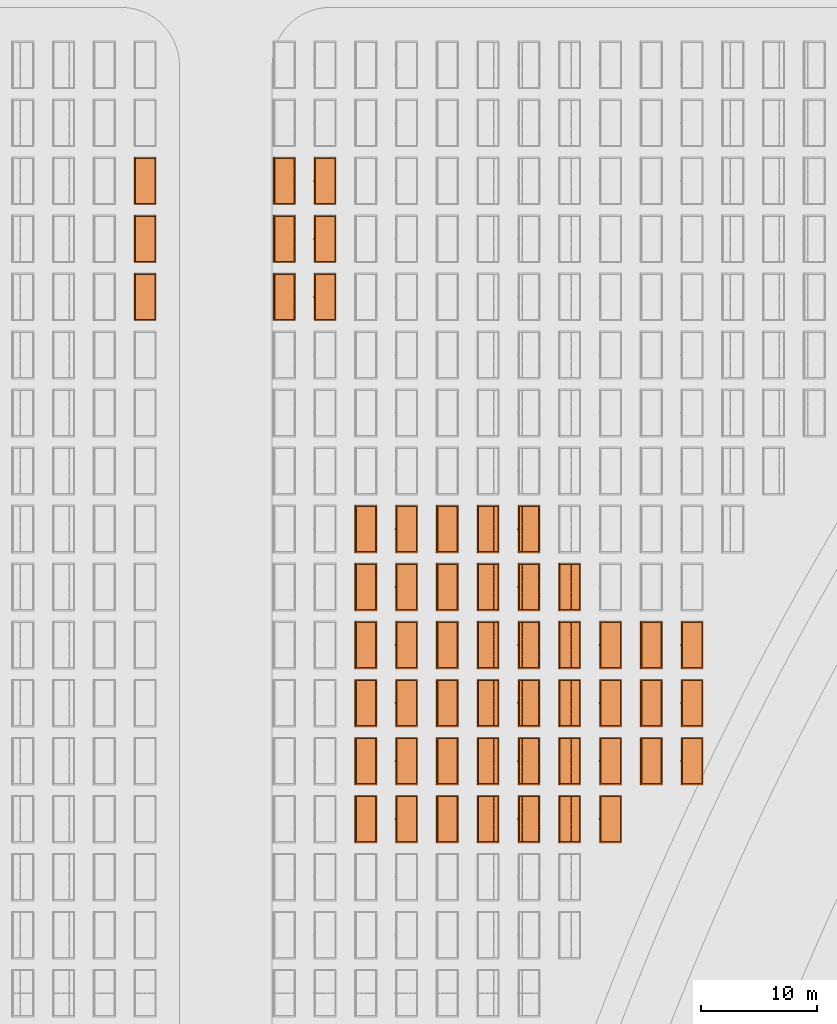
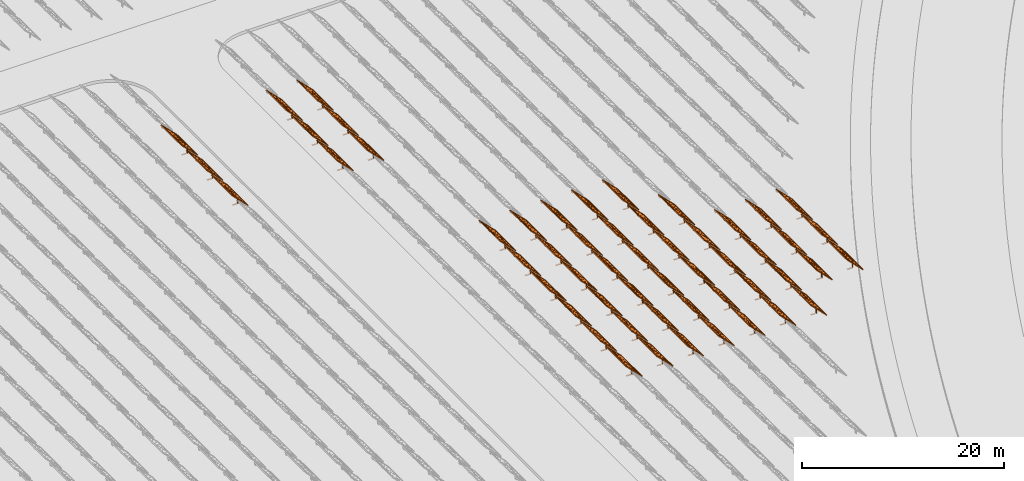
# One storey, part 30 of 39: 54 proxies.
"""IFC2X3 building model written with IfcOpenShell, lengths in millimetres."""

from ifc_helpers import new_model, entity, si_unit, converted_unit, derived_unit, direction, frame, frame_2d, origin, origin_2d_with_axis, place, context, subcontext, project, spatial, polyline, rectangle, outline, extrude, source, transform, mapped, material, material_list, element, save


model = new_model("IFC2X3")

# Units and contexts
model_context = context("Model", 3, precision=1e-06, world=origin(), true_north=direction((2.0, 6.12303176911189e-17, 1.0)))
context_of_model = context(None, 3, precision=1e-06, world=origin(), true_north=direction((2.0, 6.12303176911189e-17, 1.0)))
body_context = subcontext(model_context, "Body", "Model", "MODEL_VIEW")
ifc_project = project(units=[si_unit("LENGTHUNIT", "METRE", prefix="MILLI"), si_unit("AREAUNIT", "SQUARE_METRE", prefix="MILLI"), si_unit("VOLUMEUNIT", "CUBIC_METRE", prefix="MILLI"), converted_unit("PLANEANGLEUNIT", "DEGREE", entity("IfcRatioMeasure", 0.0174532925199433), si_unit("PLANEANGLEUNIT", "RADIAN"), dimensions=[0, 0, 0, 0, 0, 0, 0]), si_unit("MASSUNIT", "GRAM", prefix="KILO"), si_unit("TIMEUNIT", "SECOND"), si_unit("THERMODYNAMICTEMPERATUREUNIT", "KELVIN"), derived_unit("THERMALTRANSMITTANCEUNIT", [(si_unit("MASSUNIT", "GRAM", prefix="KILO"), 1), (si_unit("THERMODYNAMICTEMPERATUREUNIT", "KELVIN"), -1), (si_unit("TIMEUNIT", "SECOND"), -3)]), derived_unit("VOLUMETRICFLOWRATEUNIT", [(si_unit("LENGTHUNIT", "METRE"), 3), (si_unit("TIMEUNIT", "SECOND"), -1)])], contexts=[model_context, context_of_model])

# Site, building, storey
site_placement = place(None, origin())
site = spatial("IfcSite", under=ifc_project, at=site_placement, CompositionType="ELEMENT")
building_placement = place(site_placement, origin())
building = spatial("IfcBuilding", under=site, at=building_placement, CompositionType="ELEMENT")
storey_placement = place(building_placement, frame((0.0, 0.0, 4000.0)))
storey = spatial("IfcBuildingStorey", under=building, at=storey_placement, Name="Level 2", CompositionType="ELEMENT", Elevation=4000.0)

# Proxies
ifc_material_1 = material(Name="Stand-Steel")
ifc_material_2 = material(Name="Aluminium")
ifc_material_3 = material(Name="Glass")
ifc_material_list_1 = material_list([ifc_material_1, ifc_material_2, ifc_material_3])
shared_shape = source(origin(), body_context, "Body", "SweptSolid", [
    extrude(outline(polyline([(-629.526235435404, -220.0), (329.763117717702, -220.0), (329.763117717703, 410.0), (299.763117717703, 410.0), (299.763117717702, -190.0), (-629.526235435404, -190.0), (-629.526235435404, -220.0)])), frame((-190.00003127179, -100.0, 299.763117717707), z_axis=(0.0, 1.0, 0.0), x_axis=(0.0, 0.0, -1.0)), (0.0, 0.0, 1.0), 200.0),
    extrude(rectangle(XDim=20.0000000000001, YDim=200.0, at=frame_2d((0.0, -7.105427357601e-14), x_axis=(0.0, 1.0))), frame((-7.07109908365613, 0.0, 922.21828534124), z_axis=(-0.70710678118654, 0.0, 0.707106781186555), x_axis=(0.0, 1.0, 0.0)), (0.0, 0.0, 1.0), 2600.0),
    extrude(rectangle(XDim=24.9999999999997, YDim=24.9999999999999, at=frame_2d((2.87769807982841e-13, -9.50350909079134e-14), x_axis=(1.0, 0.0))), frame((-1449.56292018118, -1950.0, 2449.57494522722), z_axis=(0.0, 1.0, 0.0), x_axis=(-0.707106781186548, 0.0, -0.707106781186548)), (0.0, 0.0, 1.0), 3900.0),
    extrude(rectangle(XDim=24.9999999999999, YDim=25.0000000000001, at=origin_2d_with_axis()), frame((-1096.0095295879, -1950.0, 2096.02155463395), z_axis=(0.0, 1.0, 0.0), x_axis=(-0.707106781186542, 0.0, -0.707106781186553)), (0.0, 0.0, 1.0), 3900.0),
    extrude(rectangle(XDim=24.9999999999999, YDim=25.0000000000001, at=origin_2d_with_axis()), frame((-742.456138994631, -1950.0, 1742.46816404067), z_axis=(0.0, 1.0, 0.0), x_axis=(-0.707106781186542, 0.0, -0.707106781186553)), (0.0, 0.0, 1.0), 3900.0),
    extrude(rectangle(XDim=25.0, YDim=24.9999999999997, at=frame_2d((-7.19424519957101e-14, 1.19904086659517e-13), x_axis=(1.0, 0.0))), frame((-388.902748401358, -1950.0, 1388.9147734474), z_axis=(0.0, 1.0, 0.0), x_axis=(-0.707106781186545, 0.0, -0.70710678118655)), (0.0, 0.0, 1.0), 3900.0),
    extrude(rectangle(XDim=25.0000000000002, YDim=25.0, at=frame_2d((1.35891298214119e-13, 6.21724893790088e-15), x_axis=(0.0, 1.0))), frame((-35.3553703311048, 1500.0, 1035.35537033109), z_axis=(-0.707106781186544, 0.0, 0.707106781186551), x_axis=(0.0, 1.0, 0.0)), (0.0, 0.0, 1.0), 2440.0),
    extrude(rectangle(XDim=25.0000000000002, YDim=25.0, at=frame_2d((0.0, 1.77635683940025e-15), x_axis=(0.0, 1.0))), frame((-35.3553703311059, 1000.0, 1035.35537033109), z_axis=(-0.707106781186546, 0.0, 0.707106781186549), x_axis=(0.0, 1.0, 0.0)), (0.0, 0.0, 1.0), 2440.0),
    extrude(rectangle(XDim=25.0000000000002, YDim=25.0, at=frame_2d((0.0, 8.43769498715119e-14), x_axis=(0.0, 1.0))), frame((-26.5165355662756, 0.0, 1044.19420509593), z_axis=(-0.707106781186546, 0.0, 0.707106781186549), x_axis=(0.0, -1.0, 0.0)), (0.0, 0.0, 1.0), 2440.0),
    extrude(rectangle(XDim=25.0000000000002, YDim=25.0, at=frame_2d((0.0, 8.88178419700125e-16), x_axis=(0.0, 1.0))), frame((-35.3553703311065, 500.0, 1035.35537033109), z_axis=(-0.707106781186546, 0.0, 0.707106781186549), x_axis=(0.0, 1.0, 0.0)), (0.0, 0.0, 1.0), 2440.0),
    extrude(rectangle(XDim=25.0000000000002, YDim=25.0, at=frame_2d((0.0, 8.88178419700125e-16), x_axis=(0.0, 1.0))), frame((-35.3553703311086, -500.0, 1035.35537033109), z_axis=(-0.707106781186546, 0.0, 0.707106781186549), x_axis=(0.0, 1.0, 0.0)), (0.0, 0.0, 1.0), 2440.0),
    extrude(rectangle(XDim=25.0000000000002, YDim=25.0, at=frame_2d((0.0, 8.88178419700125e-16), x_axis=(0.0, 1.0))), frame((-35.3553703311095, -1000.0, 1035.35537033109), z_axis=(-0.707106781186546, 0.0, 0.707106781186549), x_axis=(0.0, 1.0, 0.0)), (0.0, 0.0, 1.0), 2440.0),
    extrude(rectangle(XDim=25.0000000000002, YDim=25.0, at=frame_2d((1.35891298214119e-13, 1.77635683940025e-15), x_axis=(0.0, 1.0))), frame((-35.3553703311107, -1500.0, 1035.35537033109), z_axis=(-0.707106781186546, 0.0, 0.707106781186549), x_axis=(0.0, 1.0, 0.0)), (0.0, 0.0, 1.0), 2440.0),
    extrude(rectangle(XDim=2400.0, YDim=11.9999999999994, at=frame_2d((-1.13686837721616e-13, 2.02948768901479e-13), x_axis=(1.0, 0.0))), frame((-883.883507754966, -1950.0, 1883.88350775495), z_axis=(0.0, 1.0, 0.0), x_axis=(0.707106781186546, 0.0, -0.707106781186549)), (0.0, 0.0, 1.0), 3900.0),
    extrude(outline(polyline([(-2050.0, -1300.0), (2050.0, -1300.0), (2050.0, 1300.0), (-2050.0, 1300.0), (-2050.0, -1300.0)]), holes=[polyline([(1950.0, -1200.0), (-1950.0, -1200.0), (-1950.0, 1200.0), (1950.0, 1200.0), (1950.0, -1200.0)])]), frame((-919.238846814293, 0.0, 1848.52816869563), z_axis=(0.707106781186554, 0.0, 0.707106781186541), x_axis=(0.0, 1.0, 0.0)), (0.0, 0.0, 1.0), 99.9999999999898),
])
proxy_1_placement = place(storey_placement, frame((-140870.317940101, 565144.680552408, 30.0)))
element("IfcBuildingElementProxy", 1, at=proxy_1_placement, inside=storey, material=ifc_material_list_1, Name="Solar Panel_4000X2500:Solar Panel_4000X2500", ObjectType="Solar Panel_4000X2500", CompositionType="ELEMENT", context=body_context, shape_type="MappedRepresentation", body=[
    mapped(shared_shape, transform((0.0, 0.0, 0.0), scale=1.0)),
])
ifc_material_list_2 = material_list([ifc_material_1, ifc_material_2, ifc_material_3])
proxy_2_placement = place(storey_placement, frame((-137355.307568371, 565144.680552408, 30.0)))
element("IfcBuildingElementProxy", 2, at=proxy_2_placement, inside=storey, material=ifc_material_list_2, Name="Solar Panel_4000X2500:Solar Panel_4000X2500", ObjectType="Solar Panel_4000X2500", CompositionType="ELEMENT", context=body_context, shape_type="MappedRepresentation", body=[
    mapped(shared_shape, transform((0.0, 0.0, 0.0), scale=1.0)),
])
ifc_material_list_3 = material_list([ifc_material_1, ifc_material_2, ifc_material_3])
proxy_3_placement = place(storey_placement, frame((-133840.297196641, 565144.680552408, 30.0)))
element("IfcBuildingElementProxy", 3, at=proxy_3_placement, inside=storey, material=ifc_material_list_3, Name="Solar Panel_4000X2500:Solar Panel_4000X2500", ObjectType="Solar Panel_4000X2500", CompositionType="ELEMENT", context=body_context, shape_type="MappedRepresentation", body=[
    mapped(shared_shape, transform((0.0, 0.0, 0.0), scale=1.0)),
])
ifc_material_list_4 = material_list([ifc_material_1, ifc_material_2, ifc_material_3])
proxy_4_placement = place(storey_placement, frame((-130325.286824911, 565144.680552408, 30.0)))
element("IfcBuildingElementProxy", 4, at=proxy_4_placement, inside=storey, material=ifc_material_list_4, Name="Solar Panel_4000X2500:Solar Panel_4000X2500", ObjectType="Solar Panel_4000X2500", CompositionType="ELEMENT", context=body_context, shape_type="MappedRepresentation", body=[
    mapped(shared_shape, transform((0.0, 0.0, 0.0), scale=1.0)),
])
ifc_material_list_5 = material_list([ifc_material_1, ifc_material_2, ifc_material_3])
proxy_5_placement = place(storey_placement, frame((-140870.317940101, 570144.680552408, 30.0)))
element("IfcBuildingElementProxy", 5, at=proxy_5_placement, inside=storey, material=ifc_material_list_5, Name="Solar Panel_4000X2500:Solar Panel_4000X2500", ObjectType="Solar Panel_4000X2500", CompositionType="ELEMENT", context=body_context, shape_type="MappedRepresentation", body=[
    mapped(shared_shape, transform((0.0, 0.0, 0.0), scale=1.0)),
])
ifc_material_list_6 = material_list([ifc_material_1, ifc_material_2, ifc_material_3])
proxy_6_placement = place(storey_placement, frame((-137355.307568371, 570144.680552408, 30.0)))
element("IfcBuildingElementProxy", 6, at=proxy_6_placement, inside=storey, material=ifc_material_list_6, Name="Solar Panel_4000X2500:Solar Panel_4000X2500", ObjectType="Solar Panel_4000X2500", CompositionType="ELEMENT", context=body_context, shape_type="MappedRepresentation", body=[
    mapped(shared_shape, transform((0.0, 0.0, 0.0), scale=1.0)),
])
ifc_material_list_7 = material_list([ifc_material_1, ifc_material_2, ifc_material_3])
proxy_7_placement = place(storey_placement, frame((-133840.297196641, 570144.680552408, 30.0)))
element("IfcBuildingElementProxy", 7, at=proxy_7_placement, inside=storey, material=ifc_material_list_7, Name="Solar Panel_4000X2500:Solar Panel_4000X2500", ObjectType="Solar Panel_4000X2500", CompositionType="ELEMENT", context=body_context, shape_type="MappedRepresentation", body=[
    mapped(shared_shape, transform((0.0, 0.0, 0.0), scale=1.0)),
])
ifc_material_list_8 = material_list([ifc_material_1, ifc_material_2, ifc_material_3])
proxy_8_placement = place(storey_placement, frame((-130325.286824911, 570144.680552408, 30.0)))
element("IfcBuildingElementProxy", 8, at=proxy_8_placement, inside=storey, material=ifc_material_list_8, Name="Solar Panel_4000X2500:Solar Panel_4000X2500", ObjectType="Solar Panel_4000X2500", CompositionType="ELEMENT", context=body_context, shape_type="MappedRepresentation", body=[
    mapped(shared_shape, transform((0.0, 0.0, 0.0), scale=1.0)),
])
ifc_material_list_9 = material_list([ifc_material_1, ifc_material_2, ifc_material_3])
proxy_9_placement = place(storey_placement, frame((-140870.317940101, 575144.680552408, 30.0)))
element("IfcBuildingElementProxy", 9, at=proxy_9_placement, inside=storey, material=ifc_material_list_9, Name="Solar Panel_4000X2500:Solar Panel_4000X2500", ObjectType="Solar Panel_4000X2500", CompositionType="ELEMENT", context=body_context, shape_type="MappedRepresentation", body=[
    mapped(shared_shape, transform((0.0, 0.0, 0.0), scale=1.0)),
])
ifc_material_list_10 = material_list([ifc_material_1, ifc_material_2, ifc_material_3])
proxy_10_placement = place(storey_placement, frame((-137355.307568371, 575144.680552408, 30.0)))
element("IfcBuildingElementProxy", 10, at=proxy_10_placement, inside=storey, material=ifc_material_list_10, Name="Solar Panel_4000X2500:Solar Panel_4000X2500", ObjectType="Solar Panel_4000X2500", CompositionType="ELEMENT", context=body_context, shape_type="MappedRepresentation", body=[
    mapped(shared_shape, transform((0.0, 0.0, 0.0), scale=1.0)),
])
ifc_material_list_11 = material_list([ifc_material_1, ifc_material_2, ifc_material_3])
proxy_11_placement = place(storey_placement, frame((-133840.297196641, 575144.680552408, 30.0)))
element("IfcBuildingElementProxy", 11, at=proxy_11_placement, inside=storey, material=ifc_material_list_11, Name="Solar Panel_4000X2500:Solar Panel_4000X2500", ObjectType="Solar Panel_4000X2500", CompositionType="ELEMENT", context=body_context, shape_type="MappedRepresentation", body=[
    mapped(shared_shape, transform((0.0, 0.0, 0.0), scale=1.0)),
])
ifc_material_list_12 = material_list([ifc_material_1, ifc_material_2, ifc_material_3])
proxy_12_placement = place(storey_placement, frame((-130325.286824911, 575144.680552408, 30.0)))
element("IfcBuildingElementProxy", 12, at=proxy_12_placement, inside=storey, material=ifc_material_list_12, Name="Solar Panel_4000X2500:Solar Panel_4000X2500", ObjectType="Solar Panel_4000X2500", CompositionType="ELEMENT", context=body_context, shape_type="MappedRepresentation", body=[
    mapped(shared_shape, transform((0.0, 0.0, 0.0), scale=1.0)),
])
ifc_material_list_13 = material_list([ifc_material_1, ifc_material_2, ifc_material_3])
proxy_13_placement = place(storey_placement, frame((-140870.317940101, 580144.680552408, 30.0)))
element("IfcBuildingElementProxy", 13, at=proxy_13_placement, inside=storey, material=ifc_material_list_13, Name="Solar Panel_4000X2500:Solar Panel_4000X2500", ObjectType="Solar Panel_4000X2500", CompositionType="ELEMENT", context=body_context, shape_type="MappedRepresentation", body=[
    mapped(shared_shape, transform((0.0, 0.0, 0.0), scale=1.0)),
])
ifc_material_list_14 = material_list([ifc_material_1, ifc_material_2, ifc_material_3])
proxy_14_placement = place(storey_placement, frame((-137355.307568371, 580144.680552408, 30.0)))
element("IfcBuildingElementProxy", 14, at=proxy_14_placement, inside=storey, material=ifc_material_list_14, Name="Solar Panel_4000X2500:Solar Panel_4000X2500", ObjectType="Solar Panel_4000X2500", CompositionType="ELEMENT", context=body_context, shape_type="MappedRepresentation", body=[
    mapped(shared_shape, transform((0.0, 0.0, 0.0), scale=1.0)),
])
ifc_material_list_15 = material_list([ifc_material_1, ifc_material_2, ifc_material_3])
proxy_15_placement = place(storey_placement, frame((-133840.297196641, 580144.680552408, 30.0)))
element("IfcBuildingElementProxy", 15, at=proxy_15_placement, inside=storey, material=ifc_material_list_15, Name="Solar Panel_4000X2500:Solar Panel_4000X2500", ObjectType="Solar Panel_4000X2500", CompositionType="ELEMENT", context=body_context, shape_type="MappedRepresentation", body=[
    mapped(shared_shape, transform((0.0, 0.0, 0.0), scale=1.0)),
])
ifc_material_list_16 = material_list([ifc_material_1, ifc_material_2, ifc_material_3])
proxy_16_placement = place(storey_placement, frame((-130325.286824911, 580144.680552408, 30.0)))
element("IfcBuildingElementProxy", 16, at=proxy_16_placement, inside=storey, material=ifc_material_list_16, Name="Solar Panel_4000X2500:Solar Panel_4000X2500", ObjectType="Solar Panel_4000X2500", CompositionType="ELEMENT", context=body_context, shape_type="MappedRepresentation", body=[
    mapped(shared_shape, transform((0.0, 0.0, 0.0), scale=1.0)),
])
ifc_material_list_17 = material_list([ifc_material_1, ifc_material_2, ifc_material_3])
proxy_17_placement = place(storey_placement, frame((-140870.317940101, 585144.680552408, 30.0)))
element("IfcBuildingElementProxy", 17, at=proxy_17_placement, inside=storey, material=ifc_material_list_17, Name="Solar Panel_4000X2500:Solar Panel_4000X2500", ObjectType="Solar Panel_4000X2500", CompositionType="ELEMENT", context=body_context, shape_type="MappedRepresentation", body=[
    mapped(shared_shape, transform((0.0, 0.0, 0.0), scale=1.0)),
])
ifc_material_list_18 = material_list([ifc_material_1, ifc_material_2, ifc_material_3])
proxy_18_placement = place(storey_placement, frame((-137355.307568371, 585144.680552408, 30.0)))
element("IfcBuildingElementProxy", 18, at=proxy_18_placement, inside=storey, material=ifc_material_list_18, Name="Solar Panel_4000X2500:Solar Panel_4000X2500", ObjectType="Solar Panel_4000X2500", CompositionType="ELEMENT", context=body_context, shape_type="MappedRepresentation", body=[
    mapped(shared_shape, transform((0.0, 0.0, 0.0), scale=1.0)),
])
ifc_material_list_19 = material_list([ifc_material_1, ifc_material_2, ifc_material_3])
proxy_19_placement = place(storey_placement, frame((-133840.297196641, 585144.680552408, 30.0)))
element("IfcBuildingElementProxy", 19, at=proxy_19_placement, inside=storey, material=ifc_material_list_19, Name="Solar Panel_4000X2500:Solar Panel_4000X2500", ObjectType="Solar Panel_4000X2500", CompositionType="ELEMENT", context=body_context, shape_type="MappedRepresentation", body=[
    mapped(shared_shape, transform((0.0, 0.0, 0.0), scale=1.0)),
])
ifc_material_list_20 = material_list([ifc_material_1, ifc_material_2, ifc_material_3])
proxy_20_placement = place(storey_placement, frame((-130325.286824911, 585144.680552408, 30.0)))
element("IfcBuildingElementProxy", 20, at=proxy_20_placement, inside=storey, material=ifc_material_list_20, Name="Solar Panel_4000X2500:Solar Panel_4000X2500", ObjectType="Solar Panel_4000X2500", CompositionType="ELEMENT", context=body_context, shape_type="MappedRepresentation", body=[
    mapped(shared_shape, transform((0.0, 0.0, 0.0), scale=1.0)),
])
ifc_material_list_21 = material_list([ifc_material_1, ifc_material_2, ifc_material_3])
proxy_21_placement = place(storey_placement, frame((-140870.317940101, 590144.680552408, 30.0)))
element("IfcBuildingElementProxy", 21, at=proxy_21_placement, inside=storey, material=ifc_material_list_21, Name="Solar Panel_4000X2500:Solar Panel_4000X2500", ObjectType="Solar Panel_4000X2500", CompositionType="ELEMENT", context=body_context, shape_type="MappedRepresentation", body=[
    mapped(shared_shape, transform((0.0, 0.0, 0.0), scale=1.0)),
])
ifc_material_list_22 = material_list([ifc_material_1, ifc_material_2, ifc_material_3])
proxy_22_placement = place(storey_placement, frame((-137355.307568371, 590144.680552408, 30.0)))
element("IfcBuildingElementProxy", 22, at=proxy_22_placement, inside=storey, material=ifc_material_list_22, Name="Solar Panel_4000X2500:Solar Panel_4000X2500", ObjectType="Solar Panel_4000X2500", CompositionType="ELEMENT", context=body_context, shape_type="MappedRepresentation", body=[
    mapped(shared_shape, transform((0.0, 0.0, 0.0), scale=1.0)),
])
ifc_material_list_23 = material_list([ifc_material_1, ifc_material_2, ifc_material_3])
proxy_23_placement = place(storey_placement, frame((-133840.297196641, 590144.680552408, 30.0)))
element("IfcBuildingElementProxy", 23, at=proxy_23_placement, inside=storey, material=ifc_material_list_23, Name="Solar Panel_4000X2500:Solar Panel_4000X2500", ObjectType="Solar Panel_4000X2500", CompositionType="ELEMENT", context=body_context, shape_type="MappedRepresentation", body=[
    mapped(shared_shape, transform((0.0, 0.0, 0.0), scale=1.0)),
])
ifc_material_list_24 = material_list([ifc_material_1, ifc_material_2, ifc_material_3])
proxy_24_placement = place(storey_placement, frame((-130325.286824911, 590144.680552408, 30.0)))
element("IfcBuildingElementProxy", 24, at=proxy_24_placement, inside=storey, material=ifc_material_list_24, Name="Solar Panel_4000X2500:Solar Panel_4000X2500", ObjectType="Solar Panel_4000X2500", CompositionType="ELEMENT", context=body_context, shape_type="MappedRepresentation", body=[
    mapped(shared_shape, transform((0.0, 0.0, 0.0), scale=1.0)),
])
ifc_material_list_25 = material_list([ifc_material_1, ifc_material_2, ifc_material_3])
proxy_25_placement = place(storey_placement, frame((-126810.276453181, 565144.680552408, 30.0)))
element("IfcBuildingElementProxy", 25, at=proxy_25_placement, inside=storey, material=ifc_material_list_25, Name="Solar Panel_4000X2500:Solar Panel_4000X2500", ObjectType="Solar Panel_4000X2500", CompositionType="ELEMENT", context=body_context, shape_type="MappedRepresentation", body=[
    mapped(shared_shape, transform((0.0, 0.0, 0.0), scale=1.0)),
])
ifc_material_list_26 = material_list([ifc_material_1, ifc_material_2, ifc_material_3])
proxy_26_placement = place(storey_placement, frame((-126810.276453181, 570144.680552408, 30.0)))
element("IfcBuildingElementProxy", 26, at=proxy_26_placement, inside=storey, material=ifc_material_list_26, Name="Solar Panel_4000X2500:Solar Panel_4000X2500", ObjectType="Solar Panel_4000X2500", CompositionType="ELEMENT", context=body_context, shape_type="MappedRepresentation", body=[
    mapped(shared_shape, transform((0.0, 0.0, 0.0), scale=1.0)),
])
ifc_material_list_27 = material_list([ifc_material_1, ifc_material_2, ifc_material_3])
proxy_27_placement = place(storey_placement, frame((-126810.276453181, 575144.680552408, 30.0)))
element("IfcBuildingElementProxy", 27, at=proxy_27_placement, inside=storey, material=ifc_material_list_27, Name="Solar Panel_4000X2500:Solar Panel_4000X2500", ObjectType="Solar Panel_4000X2500", CompositionType="ELEMENT", context=body_context, shape_type="MappedRepresentation", body=[
    mapped(shared_shape, transform((0.0, 0.0, 0.0), scale=1.0)),
])
ifc_material_list_28 = material_list([ifc_material_1, ifc_material_2, ifc_material_3])
proxy_28_placement = place(storey_placement, frame((-126810.276453181, 580144.680552408, 30.0)))
element("IfcBuildingElementProxy", 28, at=proxy_28_placement, inside=storey, material=ifc_material_list_28, Name="Solar Panel_4000X2500:Solar Panel_4000X2500", ObjectType="Solar Panel_4000X2500", CompositionType="ELEMENT", context=body_context, shape_type="MappedRepresentation", body=[
    mapped(shared_shape, transform((0.0, 0.0, 0.0), scale=1.0)),
])
ifc_material_list_29 = material_list([ifc_material_1, ifc_material_2, ifc_material_3])
proxy_29_placement = place(storey_placement, frame((-126810.276453181, 585144.680552408, 30.0)))
element("IfcBuildingElementProxy", 29, at=proxy_29_placement, inside=storey, material=ifc_material_list_29, Name="Solar Panel_4000X2500:Solar Panel_4000X2500", ObjectType="Solar Panel_4000X2500", CompositionType="ELEMENT", context=body_context, shape_type="MappedRepresentation", body=[
    mapped(shared_shape, transform((0.0, 0.0, 0.0), scale=1.0)),
])
ifc_material_list_30 = material_list([ifc_material_1, ifc_material_2, ifc_material_3])
proxy_30_placement = place(storey_placement, frame((-126810.276453181, 590144.680552408, 30.0)))
element("IfcBuildingElementProxy", 30, at=proxy_30_placement, inside=storey, material=ifc_material_list_30, Name="Solar Panel_4000X2500:Solar Panel_4000X2500", ObjectType="Solar Panel_4000X2500", CompositionType="ELEMENT", context=body_context, shape_type="MappedRepresentation", body=[
    mapped(shared_shape, transform((0.0, 0.0, 0.0), scale=1.0)),
])
ifc_material_list_31 = material_list([ifc_material_1, ifc_material_2, ifc_material_3])
proxy_31_placement = place(storey_placement, frame((-123295.266081452, 565144.680552408, 30.0)))
element("IfcBuildingElementProxy", 31, at=proxy_31_placement, inside=storey, material=ifc_material_list_31, Name="Solar Panel_4000X2500:Solar Panel_4000X2500", ObjectType="Solar Panel_4000X2500", CompositionType="ELEMENT", context=body_context, shape_type="MappedRepresentation", body=[
    mapped(shared_shape, transform((0.0, 0.0, 0.0), scale=1.0)),
])
ifc_material_list_32 = material_list([ifc_material_1, ifc_material_2, ifc_material_3])
proxy_32_placement = place(storey_placement, frame((-123295.266081452, 570144.680552408, 30.0)))
element("IfcBuildingElementProxy", 32, at=proxy_32_placement, inside=storey, material=ifc_material_list_32, Name="Solar Panel_4000X2500:Solar Panel_4000X2500", ObjectType="Solar Panel_4000X2500", CompositionType="ELEMENT", context=body_context, shape_type="MappedRepresentation", body=[
    mapped(shared_shape, transform((0.0, 0.0, 0.0), scale=1.0)),
])
ifc_material_list_33 = material_list([ifc_material_1, ifc_material_2, ifc_material_3])
proxy_33_placement = place(storey_placement, frame((-123295.266081452, 575144.680552408, 30.0)))
element("IfcBuildingElementProxy", 33, at=proxy_33_placement, inside=storey, material=ifc_material_list_33, Name="Solar Panel_4000X2500:Solar Panel_4000X2500", ObjectType="Solar Panel_4000X2500", CompositionType="ELEMENT", context=body_context, shape_type="MappedRepresentation", body=[
    mapped(shared_shape, transform((0.0, 0.0, 0.0), scale=1.0)),
])
ifc_material_list_34 = material_list([ifc_material_1, ifc_material_2, ifc_material_3])
proxy_34_placement = place(storey_placement, frame((-123295.266081452, 580144.680552408, 30.0)))
element("IfcBuildingElementProxy", 34, at=proxy_34_placement, inside=storey, material=ifc_material_list_34, Name="Solar Panel_4000X2500:Solar Panel_4000X2500", ObjectType="Solar Panel_4000X2500", CompositionType="ELEMENT", context=body_context, shape_type="MappedRepresentation", body=[
    mapped(shared_shape, transform((0.0, 0.0, 0.0), scale=1.0)),
])
ifc_material_list_35 = material_list([ifc_material_1, ifc_material_2, ifc_material_3])
proxy_35_placement = place(storey_placement, frame((-123295.266081452, 585144.680552408, 30.0)))
element("IfcBuildingElementProxy", 35, at=proxy_35_placement, inside=storey, material=ifc_material_list_35, Name="Solar Panel_4000X2500:Solar Panel_4000X2500", ObjectType="Solar Panel_4000X2500", CompositionType="ELEMENT", context=body_context, shape_type="MappedRepresentation", body=[
    mapped(shared_shape, transform((0.0, 0.0, 0.0), scale=1.0)),
])
ifc_material_list_36 = material_list([ifc_material_1, ifc_material_2, ifc_material_3])
proxy_36_placement = place(storey_placement, frame((-119780.255709722, 565144.680552408, 30.0)))
element("IfcBuildingElementProxy", 36, at=proxy_36_placement, inside=storey, material=ifc_material_list_36, Name="Solar Panel_4000X2500:Solar Panel_4000X2500", ObjectType="Solar Panel_4000X2500", CompositionType="ELEMENT", context=body_context, shape_type="MappedRepresentation", body=[
    mapped(shared_shape, transform((0.0, 0.0, 0.0), scale=1.0)),
])
ifc_material_list_37 = material_list([ifc_material_1, ifc_material_2, ifc_material_3])
proxy_37_placement = place(storey_placement, frame((-119780.255709722, 570144.680552408, 30.0)))
element("IfcBuildingElementProxy", 37, at=proxy_37_placement, inside=storey, material=ifc_material_list_37, Name="Solar Panel_4000X2500:Solar Panel_4000X2500", ObjectType="Solar Panel_4000X2500", CompositionType="ELEMENT", context=body_context, shape_type="MappedRepresentation", body=[
    mapped(shared_shape, transform((0.0, 0.0, 0.0), scale=1.0)),
])
ifc_material_list_38 = material_list([ifc_material_1, ifc_material_2, ifc_material_3])
proxy_38_placement = place(storey_placement, frame((-119780.255709722, 575144.680552408, 30.0)))
element("IfcBuildingElementProxy", 38, at=proxy_38_placement, inside=storey, material=ifc_material_list_38, Name="Solar Panel_4000X2500:Solar Panel_4000X2500", ObjectType="Solar Panel_4000X2500", CompositionType="ELEMENT", context=body_context, shape_type="MappedRepresentation", body=[
    mapped(shared_shape, transform((0.0, 0.0, 0.0), scale=1.0)),
])
ifc_material_list_39 = material_list([ifc_material_1, ifc_material_2, ifc_material_3])
proxy_39_placement = place(storey_placement, frame((-119780.255709722, 580144.680552408, 30.0)))
element("IfcBuildingElementProxy", 39, at=proxy_39_placement, inside=storey, material=ifc_material_list_39, Name="Solar Panel_4000X2500:Solar Panel_4000X2500", ObjectType="Solar Panel_4000X2500", CompositionType="ELEMENT", context=body_context, shape_type="MappedRepresentation", body=[
    mapped(shared_shape, transform((0.0, 0.0, 0.0), scale=1.0)),
])
ifc_material_list_40 = material_list([ifc_material_1, ifc_material_2, ifc_material_3])
proxy_40_placement = place(storey_placement, frame((-116265.245337992, 570144.680552408, 30.0)))
element("IfcBuildingElementProxy", 40, at=proxy_40_placement, inside=storey, material=ifc_material_list_40, Name="Solar Panel_4000X2500:Solar Panel_4000X2500", ObjectType="Solar Panel_4000X2500", CompositionType="ELEMENT", context=body_context, shape_type="MappedRepresentation", body=[
    mapped(shared_shape, transform((0.0, 0.0, 0.0), scale=1.0)),
])
ifc_material_list_41 = material_list([ifc_material_1, ifc_material_2, ifc_material_3])
proxy_41_placement = place(storey_placement, frame((-116265.245337992, 575144.680552408, 30.0)))
element("IfcBuildingElementProxy", 41, at=proxy_41_placement, inside=storey, material=ifc_material_list_41, Name="Solar Panel_4000X2500:Solar Panel_4000X2500", ObjectType="Solar Panel_4000X2500", CompositionType="ELEMENT", context=body_context, shape_type="MappedRepresentation", body=[
    mapped(shared_shape, transform((0.0, 0.0, 0.0), scale=1.0)),
])
ifc_material_list_42 = material_list([ifc_material_1, ifc_material_2, ifc_material_3])
proxy_42_placement = place(storey_placement, frame((-116265.245337992, 580144.680552408, 30.0)))
element("IfcBuildingElementProxy", 42, at=proxy_42_placement, inside=storey, material=ifc_material_list_42, Name="Solar Panel_4000X2500:Solar Panel_4000X2500", ObjectType="Solar Panel_4000X2500", CompositionType="ELEMENT", context=body_context, shape_type="MappedRepresentation", body=[
    mapped(shared_shape, transform((0.0, 0.0, 0.0), scale=1.0)),
])
ifc_material_list_43 = material_list([ifc_material_1, ifc_material_2, ifc_material_3])
proxy_43_placement = place(storey_placement, frame((-112750.234966262, 570144.680552408, 30.0)))
element("IfcBuildingElementProxy", 43, at=proxy_43_placement, inside=storey, material=ifc_material_list_43, Name="Solar Panel_4000X2500:Solar Panel_4000X2500", ObjectType="Solar Panel_4000X2500", CompositionType="ELEMENT", context=body_context, shape_type="MappedRepresentation", body=[
    mapped(shared_shape, transform((0.0, 0.0, 0.0), scale=1.0)),
])
ifc_material_list_44 = material_list([ifc_material_1, ifc_material_2, ifc_material_3])
proxy_44_placement = place(storey_placement, frame((-112750.234966262, 575144.680552408, 30.0)))
element("IfcBuildingElementProxy", 44, at=proxy_44_placement, inside=storey, material=ifc_material_list_44, Name="Solar Panel_4000X2500:Solar Panel_4000X2500", ObjectType="Solar Panel_4000X2500", CompositionType="ELEMENT", context=body_context, shape_type="MappedRepresentation", body=[
    mapped(shared_shape, transform((0.0, 0.0, 0.0), scale=1.0)),
])
ifc_material_list_45 = material_list([ifc_material_1, ifc_material_2, ifc_material_3])
proxy_45_placement = place(storey_placement, frame((-112750.234966262, 580144.680552408, 30.0)))
element("IfcBuildingElementProxy", 45, at=proxy_45_placement, inside=storey, material=ifc_material_list_45, Name="Solar Panel_4000X2500:Solar Panel_4000X2500", ObjectType="Solar Panel_4000X2500", CompositionType="ELEMENT", context=body_context, shape_type="MappedRepresentation", body=[
    mapped(shared_shape, transform((0.0, 0.0, 0.0), scale=1.0)),
])
ifc_material_list_46 = material_list([ifc_material_1, ifc_material_2, ifc_material_3])
proxy_46_placement = place(storey_placement, frame((-144385.32831183, 610144.680552408, 30.0)))
element("IfcBuildingElementProxy", 46, at=proxy_46_placement, inside=storey, material=ifc_material_list_46, Name="Solar Panel_4000X2500:Solar Panel_4000X2500", ObjectType="Solar Panel_4000X2500", CompositionType="ELEMENT", context=body_context, shape_type="MappedRepresentation", body=[
    mapped(shared_shape, transform((0.0, 0.0, 0.0), scale=1.0)),
])
ifc_material_list_47 = material_list([ifc_material_1, ifc_material_2, ifc_material_3])
proxy_47_placement = place(storey_placement, frame((-144385.32831183, 615144.680552408, 30.0)))
element("IfcBuildingElementProxy", 47, at=proxy_47_placement, inside=storey, material=ifc_material_list_47, Name="Solar Panel_4000X2500:Solar Panel_4000X2500", ObjectType="Solar Panel_4000X2500", CompositionType="ELEMENT", context=body_context, shape_type="MappedRepresentation", body=[
    mapped(shared_shape, transform((0.0, 0.0, 0.0), scale=1.0)),
])
ifc_material_list_48 = material_list([ifc_material_1, ifc_material_2, ifc_material_3])
proxy_48_placement = place(storey_placement, frame((-144385.32831183, 620144.680552408, 30.0)))
element("IfcBuildingElementProxy", 48, at=proxy_48_placement, inside=storey, material=ifc_material_list_48, Name="Solar Panel_4000X2500:Solar Panel_4000X2500", ObjectType="Solar Panel_4000X2500", CompositionType="ELEMENT", context=body_context, shape_type="MappedRepresentation", body=[
    mapped(shared_shape, transform((0.0, 0.0, 0.0), scale=1.0)),
])
ifc_material_list_49 = material_list([ifc_material_1, ifc_material_2, ifc_material_3])
proxy_49_placement = place(storey_placement, frame((-147885.32831183, 610144.680552408, 30.0)))
element("IfcBuildingElementProxy", 49, at=proxy_49_placement, inside=storey, material=ifc_material_list_49, Name="Solar Panel_4000X2500:Solar Panel_4000X2500", ObjectType="Solar Panel_4000X2500", CompositionType="ELEMENT", context=body_context, shape_type="MappedRepresentation", body=[
    mapped(shared_shape, transform((0.0, 0.0, 0.0), scale=1.0)),
])
ifc_material_list_50 = material_list([ifc_material_1, ifc_material_2, ifc_material_3])
proxy_50_placement = place(storey_placement, frame((-147885.32831183, 615144.680552408, 30.0)))
element("IfcBuildingElementProxy", 50, at=proxy_50_placement, inside=storey, material=ifc_material_list_50, Name="Solar Panel_4000X2500:Solar Panel_4000X2500", ObjectType="Solar Panel_4000X2500", CompositionType="ELEMENT", context=body_context, shape_type="MappedRepresentation", body=[
    mapped(shared_shape, transform((0.0, 0.0, 0.0), scale=1.0)),
])
ifc_material_list_51 = material_list([ifc_material_1, ifc_material_2, ifc_material_3])
proxy_51_placement = place(storey_placement, frame((-147885.32831183, 620144.680552408, 30.0)))
element("IfcBuildingElementProxy", 51, at=proxy_51_placement, inside=storey, material=ifc_material_list_51, Name="Solar Panel_4000X2500:Solar Panel_4000X2500", ObjectType="Solar Panel_4000X2500", CompositionType="ELEMENT", context=body_context, shape_type="MappedRepresentation", body=[
    mapped(shared_shape, transform((0.0, 0.0, 0.0), scale=1.0)),
])
ifc_material_list_52 = material_list([ifc_material_1, ifc_material_2, ifc_material_3])
proxy_52_placement = place(storey_placement, frame((-159885.32831183, 610144.680552408, 30.0)))
element("IfcBuildingElementProxy", 52, at=proxy_52_placement, inside=storey, material=ifc_material_list_52, Name="Solar Panel_4000X2500:Solar Panel_4000X2500", ObjectType="Solar Panel_4000X2500", CompositionType="ELEMENT", context=body_context, shape_type="MappedRepresentation", body=[
    mapped(shared_shape, transform((0.0, 0.0, 0.0), scale=1.0)),
])
ifc_material_list_53 = material_list([ifc_material_1, ifc_material_2, ifc_material_3])
proxy_53_placement = place(storey_placement, frame((-159885.32831183, 615144.680552408, 30.0)))
element("IfcBuildingElementProxy", 53, at=proxy_53_placement, inside=storey, material=ifc_material_list_53, Name="Solar Panel_4000X2500:Solar Panel_4000X2500", ObjectType="Solar Panel_4000X2500", CompositionType="ELEMENT", context=body_context, shape_type="MappedRepresentation", body=[
    mapped(shared_shape, transform((0.0, 0.0, 0.0), scale=1.0)),
])
ifc_material_list_54 = material_list([ifc_material_1, ifc_material_2, ifc_material_3])
proxy_54_placement = place(storey_placement, frame((-159885.32831183, 620144.680552408, 30.0)))
element("IfcBuildingElementProxy", 54, at=proxy_54_placement, inside=storey, material=ifc_material_list_54, Name="Solar Panel_4000X2500:Solar Panel_4000X2500", ObjectType="Solar Panel_4000X2500", CompositionType="ELEMENT", context=body_context, shape_type="MappedRepresentation", body=[
    mapped(shared_shape, transform((0.0, 0.0, 0.0), scale=1.0)),
])

save(model, "model.ifc")
